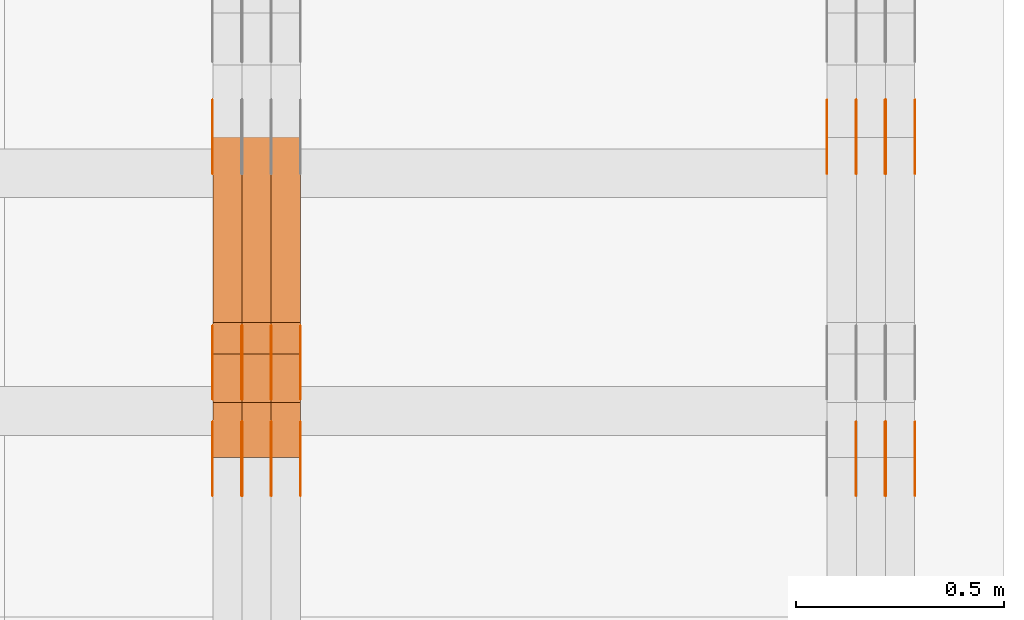
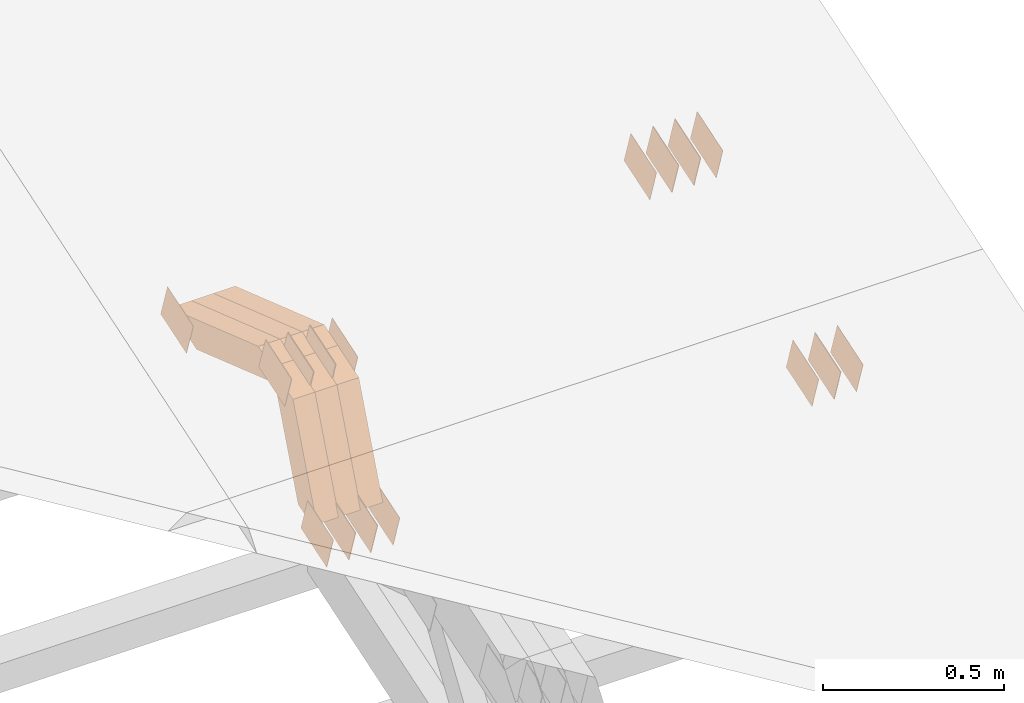
# One storey, part 311 of 385: 29 proxies.
"""IFC2X3 building model written with IfcOpenShell, lengths in millimetres."""

from ifc_helpers import new_model, entity, si_unit, converted_unit, derived_unit, direction, frame, origin, place, context, subcontext, project, spatial, polyline, outline, extrude, source, transform, mapped, material, type_object, type_shapes, element, save


model = new_model("IFC2X3")

# Units and contexts
model_context = context("Model", 3, precision=0.01, world=origin(), true_north=direction((6.12303176911189e-17, 1.0)))
body_context = subcontext(model_context, "Body", "Model", "MODEL_VIEW")
ifc_project = project(units=[si_unit("LENGTHUNIT", "METRE", prefix="MILLI"), si_unit("AREAUNIT", "SQUARE_METRE"), si_unit("VOLUMEUNIT", "CUBIC_METRE"), converted_unit("PLANEANGLEUNIT", "DEGREE", entity("IfcRatioMeasure", 0.0174532925199433), si_unit("PLANEANGLEUNIT", "RADIAN"), dimensions=[0, 0, 0, 0, 0, 0, 0]), si_unit("MASSUNIT", "GRAM", prefix="KILO"), derived_unit("MASSDENSITYUNIT", [(si_unit("MASSUNIT", "GRAM", prefix="KILO"), 1), (si_unit("LENGTHUNIT", "METRE"), -3)]), si_unit("TIMEUNIT", "SECOND"), si_unit("FREQUENCYUNIT", "HERTZ"), si_unit("THERMODYNAMICTEMPERATUREUNIT", "DEGREE_CELSIUS"), derived_unit("THERMALTRANSMITTANCEUNIT", [(si_unit("MASSUNIT", "GRAM", prefix="KILO"), 1), (si_unit("THERMODYNAMICTEMPERATUREUNIT", "KELVIN"), -1), (si_unit("TIMEUNIT", "SECOND"), -3)]), derived_unit("VOLUMETRICFLOWRATEUNIT", [(si_unit("LENGTHUNIT", "METRE"), 3), (si_unit("TIMEUNIT", "SECOND"), -1)]), si_unit("ELECTRICCURRENTUNIT", "AMPERE"), si_unit("ELECTRICVOLTAGEUNIT", "VOLT"), si_unit("POWERUNIT", "WATT"), si_unit("FORCEUNIT", "NEWTON", prefix="KILO"), si_unit("ILLUMINANCEUNIT", "LUX"), si_unit("LUMINOUSFLUXUNIT", "LUMEN"), si_unit("LUMINOUSINTENSITYUNIT", "CANDELA"), derived_unit("USERDEFINED", [(si_unit("MASSUNIT", "GRAM", prefix="KILO"), -1), (si_unit("LENGTHUNIT", "METRE"), -2), (si_unit("TIMEUNIT", "SECOND"), 3), (si_unit("LUMINOUSFLUXUNIT", "LUMEN"), 1)]), derived_unit("LINEARVELOCITYUNIT", [(si_unit("LENGTHUNIT", "METRE"), 1), (si_unit("TIMEUNIT", "SECOND"), -1)]), si_unit("PRESSUREUNIT", "PASCAL"), derived_unit("USERDEFINED", [(si_unit("LENGTHUNIT", "METRE"), -2), (si_unit("MASSUNIT", "GRAM", prefix="KILO"), 1), (si_unit("TIMEUNIT", "SECOND"), -2)])], contexts=[model_context])

# Site, building, storey
site_placement = place(None, origin())
site = spatial("IfcSite", under=ifc_project, at=site_placement, CompositionType="ELEMENT")
building_placement = place(site_placement, origin())
building = spatial("IfcBuilding", under=site, at=building_placement, CompositionType="ELEMENT")
storey_placement = place(building_placement, origin())
storey = spatial("IfcBuildingStorey", under=building, at=storey_placement, Name="Default", CompositionType="ELEMENT", Elevation=0.0)

# Proxies
ifc_material_1 = material(Name="IfcSurfaceStyle #620614")
building_element_proxy_type_1 = type_object("IfcBuildingElementProxyType", PredefinedType="NOTDEFINED", material=ifc_material_1)
shared_shape_1 = source(origin(), body_context, "Body", "SweptSolid", [
    extrude(outline(polyline([(-74.9998754286198, -60.0000016373433), (74.9998605591145, -60.0000016373433), (74.999875428618, 60.0000016373433), (-74.9998605591127, 60.0000016373433), (-74.9998754286198, -60.0000016373433)])), frame((75.0007059026038, 60.000210935219, 0.0), z_axis=(0.0, 0.0, 1.0), x_axis=(-1.0, 0.0, 0.0)), (0.0, 0.0, 1.0), 1.3),
])
type_shapes(building_element_proxy_type_1, [shared_shape_1])
proxy_1_placement = place(building_placement, frame((49861.3, 6760.15341914203, 1372.60670336718), z_axis=(-1.0, 0.0, 0.0), x_axis=(0.0, 0.951056516295124, 0.309016994375039)))
element("IfcBuildingElementProxy", 1, at=proxy_1_placement, inside=storey, type_object=building_element_proxy_type_1, material=ifc_material_1, context=body_context, shape_type="MappedRepresentation", body=[
    mapped(shared_shape_1, transform((0.0, 0.0, 0.0), scale=1.0)),
])
ifc_material_2 = material(Name="IfcSurfaceStyle #620557")
building_element_proxy_type_2 = type_object("IfcBuildingElementProxyType", PredefinedType="NOTDEFINED", material=ifc_material_2)
shared_shape_2 = source(origin(), body_context, "Body", "SweptSolid", [
    extrude(outline(polyline([(-74.9998754286198, -60.0000016373433), (74.9998605591145, -60.0000016373433), (74.999875428618, 60.0000016373433), (-74.9998605591127, 60.0000016373433), (-74.9998754286198, -60.0000016373433)])), frame((75.0007059026038, 60.000210935219, 0.0), z_axis=(0.0, 0.0, 1.0), x_axis=(-1.0, 0.0, 0.0)), (0.0, 0.0, 1.0), 1.3),
])
type_shapes(building_element_proxy_type_2, [shared_shape_2])
proxy_2_placement = place(building_placement, frame((49790.0, 6760.15341914203, 1372.60670336718), z_axis=(-1.0, 0.0, 0.0), x_axis=(0.0, 0.951056516295124, 0.309016994375039)))
element("IfcBuildingElementProxy", 2, at=proxy_2_placement, inside=storey, type_object=building_element_proxy_type_2, material=ifc_material_2, context=body_context, shape_type="MappedRepresentation", body=[
    mapped(shared_shape_2, transform((0.0, 0.0, 0.0), scale=1.0)),
])
ifc_material_3 = material(Name="IfcSurfaceStyle #620500")
building_element_proxy_type_3 = type_object("IfcBuildingElementProxyType", PredefinedType="NOTDEFINED", material=ifc_material_3)
shared_shape_3 = source(origin(), body_context, "Body", "SweptSolid", [
    extrude(outline(polyline([(-74.9998754286198, -60.0000016373433), (74.9998605591145, -60.0000016373433), (74.999875428618, 60.0000016373433), (-74.9998605591127, 60.0000016373433), (-74.9998754286198, -60.0000016373433)])), frame((75.0007059026038, 60.000210935219, 0.0), z_axis=(0.0, 0.0, 1.0), x_axis=(-1.0, 0.0, 0.0)), (0.0, 0.0, 1.0), 1.3),
])
type_shapes(building_element_proxy_type_3, [shared_shape_3])
proxy_3_placement = place(building_placement, frame((49791.3, 6760.15341914203, 1372.60670336718), z_axis=(-1.0, 0.0, 0.0), x_axis=(0.0, 0.951056516295124, 0.309016994375039)))
element("IfcBuildingElementProxy", 3, at=proxy_3_placement, inside=storey, type_object=building_element_proxy_type_3, material=ifc_material_3, context=body_context, shape_type="MappedRepresentation", body=[
    mapped(shared_shape_3, transform((0.0, 0.0, 0.0), scale=1.0)),
])
ifc_material_4 = material(Name="IfcSurfaceStyle #620443")
building_element_proxy_type_4 = type_object("IfcBuildingElementProxyType", PredefinedType="NOTDEFINED", material=ifc_material_4)
shared_shape_4 = source(origin(), body_context, "Body", "SweptSolid", [
    extrude(outline(polyline([(-74.9998754286198, -60.0000016373433), (74.9998605591145, -60.0000016373433), (74.999875428618, 60.0000016373433), (-74.9998605591127, 60.0000016373433), (-74.9998754286198, -60.0000016373433)])), frame((75.0007059026038, 60.000210935219, 0.0), z_axis=(0.0, 0.0, 1.0), x_axis=(-1.0, 0.0, 0.0)), (0.0, 0.0, 1.0), 1.29999999999999),
])
type_shapes(building_element_proxy_type_4, [shared_shape_4])
proxy_4_placement = place(building_placement, frame((49720.0, 6760.15341914203, 1372.60670336718), z_axis=(-1.0, 0.0, 0.0), x_axis=(0.0, 0.951056516295124, 0.309016994375039)))
element("IfcBuildingElementProxy", 4, at=proxy_4_placement, inside=storey, type_object=building_element_proxy_type_4, material=ifc_material_4, context=body_context, shape_type="MappedRepresentation", body=[
    mapped(shared_shape_4, transform((0.0, 0.0, 0.0), scale=1.0)),
])
ifc_material_5 = material(Name="IfcSurfaceStyle #620386")
building_element_proxy_type_5 = type_object("IfcBuildingElementProxyType", PredefinedType="NOTDEFINED", material=ifc_material_5)
shared_shape_5 = source(origin(), body_context, "Body", "SweptSolid", [
    extrude(outline(polyline([(-74.9998754286198, -60.0000016373433), (74.9998605591145, -60.0000016373433), (74.999875428618, 60.0000016373433), (-74.9998605591127, 60.0000016373433), (-74.9998754286198, -60.0000016373433)])), frame((75.0007059026038, 60.000210935219, 0.0), z_axis=(0.0, 0.0, 1.0), x_axis=(-1.0, 0.0, 0.0)), (0.0, 0.0, 1.0), 1.29999999999999),
])
type_shapes(building_element_proxy_type_5, [shared_shape_5])
proxy_5_placement = place(building_placement, frame((49721.3, 6760.15341914203, 1372.60670336718), z_axis=(-1.0, 0.0, 0.0), x_axis=(0.0, 0.951056516295124, 0.309016994375039)))
element("IfcBuildingElementProxy", 5, at=proxy_5_placement, inside=storey, type_object=building_element_proxy_type_5, material=ifc_material_5, context=body_context, shape_type="MappedRepresentation", body=[
    mapped(shared_shape_5, transform((0.0, 0.0, 0.0), scale=1.0)),
])
ifc_material_6 = material(Name="IfcSurfaceStyle #620329")
building_element_proxy_type_6 = type_object("IfcBuildingElementProxyType", PredefinedType="NOTDEFINED", material=ifc_material_6)
shared_shape_6 = source(origin(), body_context, "Body", "SweptSolid", [
    extrude(outline(polyline([(-74.9998754286198, -60.0000016373433), (74.9998605591145, -60.0000016373433), (74.999875428618, 60.0000016373433), (-74.9998605591127, 60.0000016373433), (-74.9998754286198, -60.0000016373433)])), frame((75.0007059026038, 60.000210935219, 0.0), z_axis=(0.0, 0.0, 1.0), x_axis=(-1.0, 0.0, 0.0)), (0.0, 0.0, 1.0), 1.29999999999999),
])
type_shapes(building_element_proxy_type_6, [shared_shape_6])
proxy_6_placement = place(building_placement, frame((49650.0, 6760.15341914203, 1372.60670336718), z_axis=(-1.0, 0.0, 0.0), x_axis=(0.0, 0.951056516295124, 0.309016994375039)))
element("IfcBuildingElementProxy", 6, at=proxy_6_placement, inside=storey, type_object=building_element_proxy_type_6, material=ifc_material_6, context=body_context, shape_type="MappedRepresentation", body=[
    mapped(shared_shape_6, transform((0.0, 0.0, 0.0), scale=1.0)),
])
ifc_material_7 = material(Name="IfcSurfaceStyle #614458")
building_element_proxy_type_7 = type_object("IfcBuildingElementProxyType", PredefinedType="NOTDEFINED", material=ifc_material_7)
shared_shape_7 = source(origin(), body_context, "Body", "SweptSolid", [
    extrude(outline(polyline([(-74.9998801438441, -60.0000306612856), (74.9998747047876, -60.0000306612856), (74.9998707133936, 60.0000306612856), (-74.9998652743371, 60.0000306612856), (-74.9998801438441, -60.0000306612856)])), frame((75.0000206139493, 60.0000306612856, 0.0), z_axis=(0.0, 0.0, 1.0), x_axis=(-1.0, 0.0, 0.0)), (0.0, 0.0, 1.0), 1.3),
])
type_shapes(building_element_proxy_type_7, [shared_shape_7])
proxy_7_placement = place(building_placement, frame((49861.3, 5987.08381858242, 1121.42116774683), z_axis=(-1.0, 0.0, 0.0), x_axis=(0.0, 0.951056516295124, 0.309016994375039)))
element("IfcBuildingElementProxy", 7, at=proxy_7_placement, inside=storey, type_object=building_element_proxy_type_7, material=ifc_material_7, context=body_context, shape_type="MappedRepresentation", body=[
    mapped(shared_shape_7, transform((0.0, 0.0, 0.0), scale=1.0)),
])
ifc_material_8 = material(Name="IfcSurfaceStyle #614401")
building_element_proxy_type_8 = type_object("IfcBuildingElementProxyType", PredefinedType="NOTDEFINED", material=ifc_material_8)
shared_shape_8 = source(origin(), body_context, "Body", "SweptSolid", [
    extrude(outline(polyline([(-74.9998801438441, -60.0000306612856), (74.9998747047876, -60.0000306612856), (74.9998707133936, 60.0000306612856), (-74.9998652743371, 60.0000306612856), (-74.9998801438441, -60.0000306612856)])), frame((75.0000206139493, 60.0000306612856, 0.0), z_axis=(0.0, 0.0, 1.0), x_axis=(-1.0, 0.0, 0.0)), (0.0, 0.0, 1.0), 1.3),
])
type_shapes(building_element_proxy_type_8, [shared_shape_8])
proxy_8_placement = place(building_placement, frame((49790.0, 5987.08381858242, 1121.42116774683), z_axis=(-1.0, 0.0, 0.0), x_axis=(0.0, 0.951056516295124, 0.309016994375039)))
element("IfcBuildingElementProxy", 8, at=proxy_8_placement, inside=storey, type_object=building_element_proxy_type_8, material=ifc_material_8, context=body_context, shape_type="MappedRepresentation", body=[
    mapped(shared_shape_8, transform((0.0, 0.0, 0.0), scale=1.0)),
])
ifc_material_9 = material(Name="IfcSurfaceStyle #614344")
building_element_proxy_type_9 = type_object("IfcBuildingElementProxyType", PredefinedType="NOTDEFINED", material=ifc_material_9)
shared_shape_9 = source(origin(), body_context, "Body", "SweptSolid", [
    extrude(outline(polyline([(-74.9998801438441, -60.0000306612856), (74.9998747047876, -60.0000306612856), (74.9998707133936, 60.0000306612856), (-74.9998652743371, 60.0000306612856), (-74.9998801438441, -60.0000306612856)])), frame((75.0000206139493, 60.0000306612856, 0.0), z_axis=(0.0, 0.0, 1.0), x_axis=(-1.0, 0.0, 0.0)), (0.0, 0.0, 1.0), 1.3),
])
type_shapes(building_element_proxy_type_9, [shared_shape_9])
proxy_9_placement = place(building_placement, frame((49791.3, 5987.08381858242, 1121.42116774683), z_axis=(-1.0, 0.0, 0.0), x_axis=(0.0, 0.951056516295124, 0.309016994375039)))
element("IfcBuildingElementProxy", 9, at=proxy_9_placement, inside=storey, type_object=building_element_proxy_type_9, material=ifc_material_9, context=body_context, shape_type="MappedRepresentation", body=[
    mapped(shared_shape_9, transform((0.0, 0.0, 0.0), scale=1.0)),
])
ifc_material_10 = material(Name="IfcSurfaceStyle #614287")
building_element_proxy_type_10 = type_object("IfcBuildingElementProxyType", PredefinedType="NOTDEFINED", material=ifc_material_10)
shared_shape_10 = source(origin(), body_context, "Body", "SweptSolid", [
    extrude(outline(polyline([(-74.9998801438441, -60.0000306612856), (74.9998747047876, -60.0000306612856), (74.9998707133936, 60.0000306612856), (-74.9998652743371, 60.0000306612856), (-74.9998801438441, -60.0000306612856)])), frame((75.0000206139493, 60.0000306612856, 0.0), z_axis=(0.0, 0.0, 1.0), x_axis=(-1.0, 0.0, 0.0)), (0.0, 0.0, 1.0), 1.29999999999999),
])
type_shapes(building_element_proxy_type_10, [shared_shape_10])
proxy_10_placement = place(building_placement, frame((49720.0, 5987.08381858242, 1121.42116774683), z_axis=(-1.0, 0.0, 0.0), x_axis=(0.0, 0.951056516295124, 0.309016994375039)))
element("IfcBuildingElementProxy", 10, at=proxy_10_placement, inside=storey, type_object=building_element_proxy_type_10, material=ifc_material_10, context=body_context, shape_type="MappedRepresentation", body=[
    mapped(shared_shape_10, transform((0.0, 0.0, 0.0), scale=1.0)),
])
ifc_material_11 = material(Name="IfcSurfaceStyle #585897")
building_element_proxy_type_11 = type_object("IfcBuildingElementProxyType", PredefinedType="NOTDEFINED", material=ifc_material_11)
shared_shape_11 = source(origin(), body_context, "Body", "SweptSolid", [
    extrude(outline(polyline([(-74.9998754286198, -60.0000016373433), (74.9998605591145, -60.0000016373433), (74.999875428618, 60.0000016373433), (-74.9998605591127, 60.0000016373433), (-74.9998754286198, -60.0000016373433)])), frame((75.0007059026038, 60.000210935219, 0.0), z_axis=(0.0, 0.0, 1.0), x_axis=(-1.0, 0.0, 0.0)), (0.0, 0.0, 1.0), 1.29999999999999),
])
type_shapes(building_element_proxy_type_11, [shared_shape_11])
proxy_11_placement = place(building_placement, frame((48175.0, 6760.15341914203, 1372.60670336718), z_axis=(-1.0, 0.0, 0.0), x_axis=(0.0, 0.951056516295124, 0.309016994375039)))
element("IfcBuildingElementProxy", 11, at=proxy_11_placement, inside=storey, type_object=building_element_proxy_type_11, material=ifc_material_11, context=body_context, shape_type="MappedRepresentation", body=[
    mapped(shared_shape_11, transform((0.0, 0.0, 0.0), scale=1.0)),
])
ifc_material_12 = material(Name="IfcSurfaceStyle #580026")
building_element_proxy_type_12 = type_object("IfcBuildingElementProxyType", PredefinedType="NOTDEFINED", material=ifc_material_12)
shared_shape_12 = source(origin(), body_context, "Body", "SweptSolid", [
    extrude(outline(polyline([(-74.9998801438441, -60.0000306612856), (74.9998747047876, -60.0000306612856), (74.9998707133936, 60.0000306612856), (-74.9998652743371, 60.0000306612856), (-74.9998801438441, -60.0000306612856)])), frame((75.0000206139493, 60.0000306612856, 0.0), z_axis=(0.0, 0.0, 1.0), x_axis=(-1.0, 0.0, 0.0)), (0.0, 0.0, 1.0), 1.3),
])
type_shapes(building_element_proxy_type_12, [shared_shape_12])
proxy_12_placement = place(building_placement, frame((48386.3, 5987.08381858243, 1121.42116774683), z_axis=(-1.0, 0.0, 0.0), x_axis=(0.0, 0.951056516295124, 0.309016994375039)))
element("IfcBuildingElementProxy", 12, at=proxy_12_placement, inside=storey, type_object=building_element_proxy_type_12, material=ifc_material_12, context=body_context, shape_type="MappedRepresentation", body=[
    mapped(shared_shape_12, transform((0.0, 0.0, 0.0), scale=1.0)),
])
ifc_material_13 = material(Name="IfcSurfaceStyle #579969")
building_element_proxy_type_13 = type_object("IfcBuildingElementProxyType", PredefinedType="NOTDEFINED", material=ifc_material_13)
shared_shape_13 = source(origin(), body_context, "Body", "SweptSolid", [
    extrude(outline(polyline([(-74.9998801438441, -60.0000306612856), (74.9998747047876, -60.0000306612856), (74.9998707133936, 60.0000306612856), (-74.9998652743371, 60.0000306612856), (-74.9998801438441, -60.0000306612856)])), frame((75.0000206139493, 60.0000306612856, 0.0), z_axis=(0.0, 0.0, 1.0), x_axis=(-1.0, 0.0, 0.0)), (0.0, 0.0, 1.0), 1.3),
])
type_shapes(building_element_proxy_type_13, [shared_shape_13])
proxy_13_placement = place(building_placement, frame((48315.0, 5987.08381858243, 1121.42116774683), z_axis=(-1.0, 0.0, 0.0), x_axis=(0.0, 0.951056516295124, 0.309016994375039)))
element("IfcBuildingElementProxy", 13, at=proxy_13_placement, inside=storey, type_object=building_element_proxy_type_13, material=ifc_material_13, context=body_context, shape_type="MappedRepresentation", body=[
    mapped(shared_shape_13, transform((0.0, 0.0, 0.0), scale=1.0)),
])
ifc_material_14 = material(Name="IfcSurfaceStyle #579912")
building_element_proxy_type_14 = type_object("IfcBuildingElementProxyType", PredefinedType="NOTDEFINED", material=ifc_material_14)
shared_shape_14 = source(origin(), body_context, "Body", "SweptSolid", [
    extrude(outline(polyline([(-74.9998801438441, -60.0000306612856), (74.9998747047876, -60.0000306612856), (74.9998707133936, 60.0000306612856), (-74.9998652743371, 60.0000306612856), (-74.9998801438441, -60.0000306612856)])), frame((75.0000206139493, 60.0000306612856, 0.0), z_axis=(0.0, 0.0, 1.0), x_axis=(-1.0, 0.0, 0.0)), (0.0, 0.0, 1.0), 1.3),
])
type_shapes(building_element_proxy_type_14, [shared_shape_14])
proxy_14_placement = place(building_placement, frame((48316.3, 5987.08381858243, 1121.42116774683), z_axis=(-1.0, 0.0, 0.0), x_axis=(0.0, 0.951056516295124, 0.309016994375039)))
element("IfcBuildingElementProxy", 14, at=proxy_14_placement, inside=storey, type_object=building_element_proxy_type_14, material=ifc_material_14, context=body_context, shape_type="MappedRepresentation", body=[
    mapped(shared_shape_14, transform((0.0, 0.0, 0.0), scale=1.0)),
])
ifc_material_15 = material(Name="IfcSurfaceStyle #579855")
building_element_proxy_type_15 = type_object("IfcBuildingElementProxyType", PredefinedType="NOTDEFINED", material=ifc_material_15)
shared_shape_15 = source(origin(), body_context, "Body", "SweptSolid", [
    extrude(outline(polyline([(-74.9998801438441, -60.0000306612856), (74.9998747047876, -60.0000306612856), (74.9998707133936, 60.0000306612856), (-74.9998652743371, 60.0000306612856), (-74.9998801438441, -60.0000306612856)])), frame((75.0000206139493, 60.0000306612856, 0.0), z_axis=(0.0, 0.0, 1.0), x_axis=(-1.0, 0.0, 0.0)), (0.0, 0.0, 1.0), 1.29999999999999),
])
type_shapes(building_element_proxy_type_15, [shared_shape_15])
proxy_15_placement = place(building_placement, frame((48245.0, 5987.08381858243, 1121.42116774683), z_axis=(-1.0, 0.0, 0.0), x_axis=(0.0, 0.951056516295124, 0.309016994375039)))
element("IfcBuildingElementProxy", 15, at=proxy_15_placement, inside=storey, type_object=building_element_proxy_type_15, material=ifc_material_15, context=body_context, shape_type="MappedRepresentation", body=[
    mapped(shared_shape_15, transform((0.0, 0.0, 0.0), scale=1.0)),
])
ifc_material_16 = material(Name="IfcSurfaceStyle #579798")
building_element_proxy_type_16 = type_object("IfcBuildingElementProxyType", PredefinedType="NOTDEFINED", material=ifc_material_16)
shared_shape_16 = source(origin(), body_context, "Body", "SweptSolid", [
    extrude(outline(polyline([(-74.9998801438441, -60.0000306612856), (74.9998747047876, -60.0000306612856), (74.9998707133936, 60.0000306612856), (-74.9998652743371, 60.0000306612856), (-74.9998801438441, -60.0000306612856)])), frame((75.0000206139493, 60.0000306612856, 0.0), z_axis=(0.0, 0.0, 1.0), x_axis=(-1.0, 0.0, 0.0)), (0.0, 0.0, 1.0), 1.29999999999999),
])
type_shapes(building_element_proxy_type_16, [shared_shape_16])
proxy_16_placement = place(building_placement, frame((48246.3, 5987.08381858243, 1121.42116774683), z_axis=(-1.0, 0.0, 0.0), x_axis=(0.0, 0.951056516295124, 0.309016994375039)))
element("IfcBuildingElementProxy", 16, at=proxy_16_placement, inside=storey, type_object=building_element_proxy_type_16, material=ifc_material_16, context=body_context, shape_type="MappedRepresentation", body=[
    mapped(shared_shape_16, transform((0.0, 0.0, 0.0), scale=1.0)),
])
ifc_material_17 = material(Name="IfcSurfaceStyle #579741")
building_element_proxy_type_17 = type_object("IfcBuildingElementProxyType", PredefinedType="NOTDEFINED", material=ifc_material_17)
shared_shape_17 = source(origin(), body_context, "Body", "SweptSolid", [
    extrude(outline(polyline([(-74.9998801438441, -60.0000306612856), (74.9998747047876, -60.0000306612856), (74.9998707133936, 60.0000306612856), (-74.9998652743371, 60.0000306612856), (-74.9998801438441, -60.0000306612856)])), frame((75.0000206139493, 60.0000306612856, 0.0), z_axis=(0.0, 0.0, 1.0), x_axis=(-1.0, 0.0, 0.0)), (0.0, 0.0, 1.0), 1.29999999999999),
])
type_shapes(building_element_proxy_type_17, [shared_shape_17])
proxy_17_placement = place(building_placement, frame((48175.0, 5987.08381858243, 1121.42116774683), z_axis=(-1.0, 0.0, 0.0), x_axis=(0.0, 0.951056516295124, 0.309016994375039)))
element("IfcBuildingElementProxy", 17, at=proxy_17_placement, inside=storey, type_object=building_element_proxy_type_17, material=ifc_material_17, context=body_context, shape_type="MappedRepresentation", body=[
    mapped(shared_shape_17, transform((0.0, 0.0, 0.0), scale=1.0)),
])
ifc_material_18 = material(Name="IfcSurfaceStyle #575580")
building_element_proxy_type_18 = type_object("IfcBuildingElementProxyType", PredefinedType="NOTDEFINED", material=ifc_material_18)
shared_shape_18 = source(origin(), body_context, "Body", "SweptSolid", [
    extrude(outline(polyline([(-74.9998754286253, -60.0000016373506), (74.999860559109, -60.0000016373506), (74.9998754286235, 60.0000016373506), (-74.9998605591072, 60.0000016373506), (-74.9998754286253, -60.0000016373506)])), frame((75.0001009411744, 60.0000279841752, 0.0), z_axis=(0.0, 0.0, 1.0), x_axis=(-1.0, 0.0, 0.0)), (0.0, 0.0, 1.0), 1.3),
])
type_shapes(building_element_proxy_type_18, [shared_shape_18])
proxy_18_placement = place(building_placement, frame((48386.3, 6218.29662915453, 1523.23574463408), z_axis=(-1.0, 0.0, 0.0), x_axis=(0.0, 0.951056516295154, 0.309016994374948)))
element("IfcBuildingElementProxy", 18, at=proxy_18_placement, inside=storey, type_object=building_element_proxy_type_18, material=ifc_material_18, context=body_context, shape_type="MappedRepresentation", body=[
    mapped(shared_shape_18, transform((0.0, 0.0, 0.0), scale=1.0)),
])
ifc_material_19 = material(Name="IfcSurfaceStyle #575523")
building_element_proxy_type_19 = type_object("IfcBuildingElementProxyType", PredefinedType="NOTDEFINED", material=ifc_material_19)
shared_shape_19 = source(origin(), body_context, "Body", "SweptSolid", [
    extrude(outline(polyline([(-74.9998754286253, -60.0000016373506), (74.999860559109, -60.0000016373506), (74.9998754286235, 60.0000016373506), (-74.9998605591072, 60.0000016373506), (-74.9998754286253, -60.0000016373506)])), frame((75.0001009411744, 60.0000279841752, 0.0), z_axis=(0.0, 0.0, 1.0), x_axis=(-1.0, 0.0, 0.0)), (0.0, 0.0, 1.0), 1.3),
])
type_shapes(building_element_proxy_type_19, [shared_shape_19])
proxy_19_placement = place(building_placement, frame((48315.0, 6218.29662915453, 1523.23574463408), z_axis=(-1.0, 0.0, 0.0), x_axis=(0.0, 0.951056516295154, 0.309016994374948)))
element("IfcBuildingElementProxy", 19, at=proxy_19_placement, inside=storey, type_object=building_element_proxy_type_19, material=ifc_material_19, context=body_context, shape_type="MappedRepresentation", body=[
    mapped(shared_shape_19, transform((0.0, 0.0, 0.0), scale=1.0)),
])
ifc_material_20 = material(Name="IfcSurfaceStyle #575466")
building_element_proxy_type_20 = type_object("IfcBuildingElementProxyType", PredefinedType="NOTDEFINED", material=ifc_material_20)
shared_shape_20 = source(origin(), body_context, "Body", "SweptSolid", [
    extrude(outline(polyline([(-74.9998754286253, -60.0000016373506), (74.999860559109, -60.0000016373506), (74.9998754286235, 60.0000016373506), (-74.9998605591072, 60.0000016373506), (-74.9998754286253, -60.0000016373506)])), frame((75.0001009411744, 60.0000279841752, 0.0), z_axis=(0.0, 0.0, 1.0), x_axis=(-1.0, 0.0, 0.0)), (0.0, 0.0, 1.0), 1.3),
])
type_shapes(building_element_proxy_type_20, [shared_shape_20])
proxy_20_placement = place(building_placement, frame((48316.3, 6218.29662915453, 1523.23574463408), z_axis=(-1.0, 0.0, 0.0), x_axis=(0.0, 0.951056516295154, 0.309016994374948)))
element("IfcBuildingElementProxy", 20, at=proxy_20_placement, inside=storey, type_object=building_element_proxy_type_20, material=ifc_material_20, context=body_context, shape_type="MappedRepresentation", body=[
    mapped(shared_shape_20, transform((0.0, 0.0, 0.0), scale=1.0)),
])
ifc_material_21 = material(Name="IfcSurfaceStyle #575409")
building_element_proxy_type_21 = type_object("IfcBuildingElementProxyType", PredefinedType="NOTDEFINED", material=ifc_material_21)
shared_shape_21 = source(origin(), body_context, "Body", "SweptSolid", [
    extrude(outline(polyline([(-74.9998754286253, -60.0000016373506), (74.999860559109, -60.0000016373506), (74.9998754286235, 60.0000016373506), (-74.9998605591072, 60.0000016373506), (-74.9998754286253, -60.0000016373506)])), frame((75.0001009411744, 60.0000279841752, 0.0), z_axis=(0.0, 0.0, 1.0), x_axis=(-1.0, 0.0, 0.0)), (0.0, 0.0, 1.0), 1.29999999999999),
])
type_shapes(building_element_proxy_type_21, [shared_shape_21])
proxy_21_placement = place(building_placement, frame((48245.0, 6218.29662915453, 1523.23574463408), z_axis=(-1.0, 0.0, 0.0), x_axis=(0.0, 0.951056516295154, 0.309016994374948)))
element("IfcBuildingElementProxy", 21, at=proxy_21_placement, inside=storey, type_object=building_element_proxy_type_21, material=ifc_material_21, context=body_context, shape_type="MappedRepresentation", body=[
    mapped(shared_shape_21, transform((0.0, 0.0, 0.0), scale=1.0)),
])
ifc_material_22 = material(Name="IfcSurfaceStyle #575352")
building_element_proxy_type_22 = type_object("IfcBuildingElementProxyType", PredefinedType="NOTDEFINED", material=ifc_material_22)
shared_shape_22 = source(origin(), body_context, "Body", "SweptSolid", [
    extrude(outline(polyline([(-74.9998754286253, -60.0000016373506), (74.999860559109, -60.0000016373506), (74.9998754286235, 60.0000016373506), (-74.9998605591072, 60.0000016373506), (-74.9998754286253, -60.0000016373506)])), frame((75.0001009411744, 60.0000279841752, 0.0), z_axis=(0.0, 0.0, 1.0), x_axis=(-1.0, 0.0, 0.0)), (0.0, 0.0, 1.0), 1.29999999999999),
])
type_shapes(building_element_proxy_type_22, [shared_shape_22])
proxy_22_placement = place(building_placement, frame((48246.3, 6218.29662915453, 1523.23574463408), z_axis=(-1.0, 0.0, 0.0), x_axis=(0.0, 0.951056516295154, 0.309016994374948)))
element("IfcBuildingElementProxy", 22, at=proxy_22_placement, inside=storey, type_object=building_element_proxy_type_22, material=ifc_material_22, context=body_context, shape_type="MappedRepresentation", body=[
    mapped(shared_shape_22, transform((0.0, 0.0, 0.0), scale=1.0)),
])
ifc_material_23 = material(Name="IfcSurfaceStyle #575295")
building_element_proxy_type_23 = type_object("IfcBuildingElementProxyType", PredefinedType="NOTDEFINED", material=ifc_material_23)
shared_shape_23 = source(origin(), body_context, "Body", "SweptSolid", [
    extrude(outline(polyline([(-74.9998754286253, -60.0000016373506), (74.999860559109, -60.0000016373506), (74.9998754286235, 60.0000016373506), (-74.9998605591072, 60.0000016373506), (-74.9998754286253, -60.0000016373506)])), frame((75.0001009411744, 60.0000279841752, 0.0), z_axis=(0.0, 0.0, 1.0), x_axis=(-1.0, 0.0, 0.0)), (0.0, 0.0, 1.0), 1.29999999999999),
])
type_shapes(building_element_proxy_type_23, [shared_shape_23])
proxy_23_placement = place(building_placement, frame((48175.0, 6218.29662915453, 1523.23574463408), z_axis=(-1.0, 0.0, 0.0), x_axis=(0.0, 0.951056516295154, 0.309016994374948)))
element("IfcBuildingElementProxy", 23, at=proxy_23_placement, inside=storey, type_object=building_element_proxy_type_23, material=ifc_material_23, context=body_context, shape_type="MappedRepresentation", body=[
    mapped(shared_shape_23, transform((0.0, 0.0, 0.0), scale=1.0)),
])
ifc_material_24 = material(Name="IfcSurfaceStyle #562584")
building_element_proxy_type_24 = type_object("IfcBuildingElementProxyType", Name="T1-W19 562582", PredefinedType="NOTDEFINED", material=ifc_material_24)
shared_shape_24 = source(origin(), body_context, "Body", "SweptSolid", [
    extrude(outline(polyline([(-234.986199656822, -47.5000587840676), (221.224626701627, -47.5000587840676), (219.29748584664, -9.04449542012076e-05), (156.014457007826, 47.5001040065446), (-361.550369899272, 47.5001040065447), (-234.986199656822, -47.5000587840676)])), frame((221.224626701627, 47.5001108598228, 0.0), z_axis=(0.0, 0.0, 1.0), x_axis=(-1.0, 0.0, 0.0)), (0.0, 0.0, 1.0), 70.0),
])
type_shapes(building_element_proxy_type_24, [shared_shape_24])
proxy_24_placement = place(building_placement, frame((48385.0, 6342.40425701111, 1541.63383639481), z_axis=(-1.0, 0.0, 0.0), x_axis=(0.0, 0.9461301511345, -0.323786561046329)))
element("IfcBuildingElementProxy", 24, at=proxy_24_placement, inside=storey, type_object=building_element_proxy_type_24, material=ifc_material_24, Name="T1-W19", context=body_context, shape_type="MappedRepresentation", body=[
    mapped(shared_shape_24, transform((0.0, 0.0, 0.0), scale=1.0)),
])
ifc_material_25 = material(Name="IfcSurfaceStyle #562518")
building_element_proxy_type_25 = type_object("IfcBuildingElementProxyType", Name="T1-W19 562516", PredefinedType="NOTDEFINED", material=ifc_material_25)
shared_shape_25 = source(origin(), body_context, "Body", "SweptSolid", [
    extrude(outline(polyline([(-234.986199656822, -47.5000587840676), (221.224626701627, -47.5000587840676), (219.29748584664, -9.04449542012076e-05), (156.014457007826, 47.5001040065446), (-361.550369899272, 47.5001040065447), (-234.986199656822, -47.5000587840676)])), frame((221.224626701627, 47.5001108598228, 0.0), z_axis=(0.0, 0.0, 1.0), x_axis=(-1.0, 0.0, 0.0)), (0.0, 0.0, 1.0), 70.0),
])
type_shapes(building_element_proxy_type_25, [shared_shape_25])
proxy_25_placement = place(building_placement, frame((48315.0, 6342.40425701111, 1541.63383639481), z_axis=(-1.0, 0.0, 0.0), x_axis=(0.0, 0.9461301511345, -0.323786561046329)))
element("IfcBuildingElementProxy", 25, at=proxy_25_placement, inside=storey, type_object=building_element_proxy_type_25, material=ifc_material_25, Name="T1-W19", context=body_context, shape_type="MappedRepresentation", body=[
    mapped(shared_shape_25, transform((0.0, 0.0, 0.0), scale=1.0)),
])
ifc_material_26 = material(Name="IfcSurfaceStyle #562452")
building_element_proxy_type_26 = type_object("IfcBuildingElementProxyType", Name="T1-W19 562450", PredefinedType="NOTDEFINED", material=ifc_material_26)
shared_shape_26 = source(origin(), body_context, "Body", "SweptSolid", [
    extrude(outline(polyline([(-234.986199656822, -47.5000587840676), (221.224626701627, -47.5000587840676), (219.29748584664, -9.04449542012076e-05), (156.014457007826, 47.5001040065446), (-361.550369899272, 47.5001040065447), (-234.986199656822, -47.5000587840676)])), frame((221.224626701627, 47.5001108598228, 0.0), z_axis=(0.0, 0.0, 1.0), x_axis=(-1.0, 0.0, 0.0)), (0.0, 0.0, 1.0), 70.0),
])
type_shapes(building_element_proxy_type_26, [shared_shape_26])
proxy_26_placement = place(building_placement, frame((48245.0, 6342.40425701111, 1541.63383639481), z_axis=(-1.0, 0.0, 0.0), x_axis=(0.0, 0.9461301511345, -0.323786561046329)))
element("IfcBuildingElementProxy", 26, at=proxy_26_placement, inside=storey, type_object=building_element_proxy_type_26, material=ifc_material_26, Name="T1-W19", context=body_context, shape_type="MappedRepresentation", body=[
    mapped(shared_shape_26, transform((0.0, 0.0, 0.0), scale=1.0)),
])
ifc_material_27 = material(Name="IfcSurfaceStyle #562188")
building_element_proxy_type_27 = type_object("IfcBuildingElementProxyType", Name="T1-W46 562186", PredefinedType="NOTDEFINED", material=ifc_material_27)
shared_shape_27 = source(origin(), body_context, "Body", "SweptSolid", [
    extrude(outline(polyline([(-272.224583017384, -47.5002947748381), (128.798007350946, -47.5002947748382), (167.560249082673, 0.000339032424879266), (170.567132940603, 47.500741369691), (-194.700806356838, 47.4995091475604), (-272.224583017384, -47.5002947748381)])), frame((170.567293182179, 47.5001659655231, 0.0), z_axis=(0.0, 0.0, 1.0), x_axis=(-1.0, 3.37347464168628e-06, 0.0)), (0.0, 0.0, 1.0), 70.0),
])
type_shapes(building_element_proxy_type_27, [shared_shape_27])
proxy_27_placement = place(building_placement, frame((48385.0, 6080.04687500001, 1117.66674804688), z_axis=(-1.0, 0.0, 0.0), x_axis=(0.0, 0.361885618189232, 0.93222250527854)))
element("IfcBuildingElementProxy", 27, at=proxy_27_placement, inside=storey, type_object=building_element_proxy_type_27, material=ifc_material_27, Name="T1-W46", context=body_context, shape_type="MappedRepresentation", body=[
    mapped(shared_shape_27, transform((0.0, 0.0, 0.0), scale=1.0)),
])
ifc_material_28 = material(Name="IfcSurfaceStyle #562122")
building_element_proxy_type_28 = type_object("IfcBuildingElementProxyType", Name="T1-W46 562120", PredefinedType="NOTDEFINED", material=ifc_material_28)
shared_shape_28 = source(origin(), body_context, "Body", "SweptSolid", [
    extrude(outline(polyline([(-272.224583017384, -47.5002947748381), (128.798007350946, -47.5002947748382), (167.560249082673, 0.000339032424879266), (170.567132940603, 47.500741369691), (-194.700806356838, 47.4995091475604), (-272.224583017384, -47.5002947748381)])), frame((170.567293182179, 47.5001659655231, 0.0), z_axis=(0.0, 0.0, 1.0), x_axis=(-1.0, 3.37347464168628e-06, 0.0)), (0.0, 0.0, 1.0), 70.0),
])
type_shapes(building_element_proxy_type_28, [shared_shape_28])
proxy_28_placement = place(building_placement, frame((48315.0, 6080.04687500001, 1117.66674804688), z_axis=(-1.0, 0.0, 0.0), x_axis=(0.0, 0.361885618189232, 0.93222250527854)))
element("IfcBuildingElementProxy", 28, at=proxy_28_placement, inside=storey, type_object=building_element_proxy_type_28, material=ifc_material_28, Name="T1-W46", context=body_context, shape_type="MappedRepresentation", body=[
    mapped(shared_shape_28, transform((0.0, 0.0, 0.0), scale=1.0)),
])
ifc_material_29 = material(Name="IfcSurfaceStyle #562056")
building_element_proxy_type_29 = type_object("IfcBuildingElementProxyType", Name="T1-W46 562054", PredefinedType="NOTDEFINED", material=ifc_material_29)
shared_shape_29 = source(origin(), body_context, "Body", "SweptSolid", [
    extrude(outline(polyline([(-272.224583017384, -47.5002947748381), (128.798007350946, -47.5002947748382), (167.560249082673, 0.000339032424879266), (170.567132940603, 47.500741369691), (-194.700806356838, 47.4995091475604), (-272.224583017384, -47.5002947748381)])), frame((170.567293182179, 47.5001659655231, 0.0), z_axis=(0.0, 0.0, 1.0), x_axis=(-1.0, 3.37347464168628e-06, 0.0)), (0.0, 0.0, 1.0), 70.0),
])
type_shapes(building_element_proxy_type_29, [shared_shape_29])
proxy_29_placement = place(building_placement, frame((48245.0, 6080.04687500001, 1117.66674804688), z_axis=(-1.0, 0.0, 0.0), x_axis=(0.0, 0.361885618189232, 0.93222250527854)))
element("IfcBuildingElementProxy", 29, at=proxy_29_placement, inside=storey, type_object=building_element_proxy_type_29, material=ifc_material_29, Name="T1-W46", context=body_context, shape_type="MappedRepresentation", body=[
    mapped(shared_shape_29, transform((0.0, 0.0, 0.0), scale=1.0)),
])

save(model, "model.ifc")
